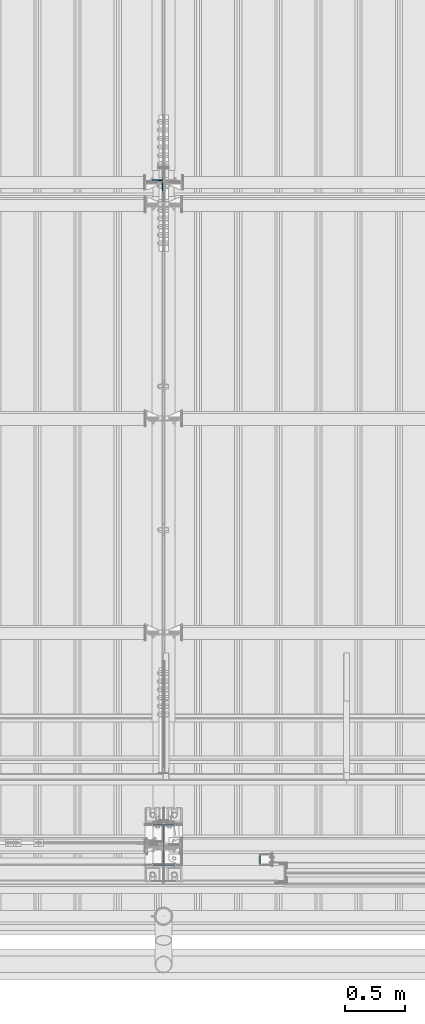
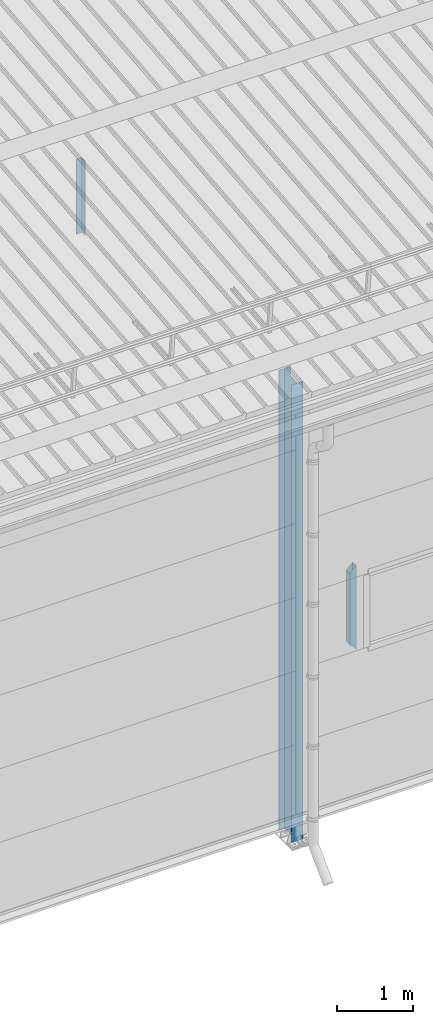
# One storey, part 229 of 709: 3 columns, 3 elements without a shape of their own.
"""IFC4 building model written with IfcOpenShell, lengths in millimetres."""

from ifc_helpers import new_model, si_unit, direction, frame, origin_with_axes, place, context, subcontext, project, spatial, polygons, material, element, aggregate, save


model = new_model("IFC4")

# Units and contexts
model_context = context("Model", 3, precision=0.2, world=origin_with_axes(), true_north=direction((0.0, 1.0)))
body_context = subcontext(model_context, "Body", "Model", "MODEL_VIEW")
ifc_project = project(units=[si_unit("LENGTHUNIT", "METRE", prefix="MILLI"), si_unit("AREAUNIT", "SQUARE_METRE"), si_unit("VOLUMEUNIT", "CUBIC_METRE"), si_unit("MASSUNIT", "GRAM", prefix="KILO"), si_unit("TIMEUNIT", "SECOND"), si_unit("PLANEANGLEUNIT", "RADIAN"), si_unit("SOLIDANGLEUNIT", "STERADIAN"), si_unit("THERMODYNAMICTEMPERATUREUNIT", "DEGREE_CELSIUS"), si_unit("LUMINOUSINTENSITYUNIT", "LUMEN")], contexts=[model_context])

# Site, building, storey
site_placement = place(None, origin_with_axes())
site = spatial("IfcSite", under=ifc_project, at=site_placement, CompositionType="ELEMENT")
building_placement = place(site_placement, origin_with_axes())
building = spatial("IfcBuilding", under=site, at=building_placement, Name="Undefined", CompositionType="ELEMENT")
storey_placement = place(building_placement, origin_with_axes())
storey = spatial("IfcBuildingStorey", under=building, at=storey_placement, Name="Undefined", CompositionType="ELEMENT", Elevation=0.0)

# Assembly, column
assembly_1_placement = place(storey_placement, frame((27949.0, 5648.7, 6024.30002), z_axis=(0.0, -1.0, 0.0), x_axis=(0.0, 0.0, 1.0)))
assembly_1 = element("IfcElementAssembly", 1, at=assembly_1_placement, inside=storey)
ifc_material_1 = material(Name="C345-5", Category="STEEL")
column_1_placement = place(assembly_1_placement, origin_with_axes())
column_1 = element("IfcColumn", 2, at=column_1_placement, material=ifc_material_1, ObjectType="436", context=body_context, shape_type="Tessellation", body=[
    polygons([(185.7, -45.0, -45.0), (185.7, 45.0, -45.0), (1399.0509, 45.0, -45.0), (1399.0509, -45.0, -45.0), (185.7, 45.0, -39.0), (1399.0509, 45.0, -39.0), (185.7, -39.0, -39.0), (1399.0509, -39.0, -39.0), (185.7, -39.0, 45.0), (1399.0509, -39.0, 45.0), (185.7, -45.0, 45.0), (1399.0509, -45.0, 45.0)], [[[1, 2, 3, 4]], [[2, 5, 6, 3]], [[5, 7, 8, 6]], [[7, 9, 10, 8]], [[9, 11, 12, 10]], [[11, 1, 4, 12]], [[6, 8, 10, 12, 4, 3]], [[11, 9, 7, 5, 2, 1]]], closed=True),
])
aggregate(assembly_1, [column_1])

assembly_2_placement = place(storey_placement, frame((28000.0, 173.0, -200.0), z_axis=(-1.0, 0.0, 0.0), x_axis=(0.0, 0.0, 1.0)))
assembly_2 = element("IfcElementAssembly", 3, at=assembly_2_placement, inside=storey)
ifc_material_2 = material(Name="C355-5", Category="STEEL")
column_2_placement = place(assembly_2_placement, origin_with_axes())
column_2 = element("IfcColumn", 4, at=column_2_placement, material=ifc_material_2, ObjectType="413", context=body_context, shape_type="Tessellation", body=[
    polygons([(25.0, -173.0, -87.0), (25.0, -164.0, -87.0), (7421.82297, -164.0, -87.0), (7420.92297, -173.0, -87.0), (25.0, -164.0, -3.0), (7421.82297, -164.0, -3.0), (25.0, 164.0, -3.0), (7454.62297, 164.0, -3.0), (25.0, 164.0, -87.0), (7454.62297, 164.0, -87.0), (25.0, 173.0, -87.0), (7455.52297, 173.0, -87.0), (25.0, 173.0, 87.0), (7455.52297, 173.0, 87.0), (25.0, 164.0, 87.0), (7454.62297, 164.0, 87.0), (25.0, 164.0, 3.0), (7454.62297, 164.0, 3.0), (25.0, -164.0, 3.0), (7421.82297, -164.0, 3.0), (25.0, -164.0, 87.0), (7421.82297, -164.0, 87.0), (25.0, -173.0, 87.0), (7420.92297, -173.0, 87.0)], [[[1, 2, 3, 4]], [[2, 5, 6, 3]], [[5, 7, 8, 6]], [[7, 9, 10, 8]], [[9, 11, 12, 10]], [[11, 13, 14, 12]], [[13, 15, 16, 14]], [[15, 17, 18, 16]], [[17, 19, 20, 18]], [[19, 21, 22, 20]], [[21, 23, 24, 22]], [[23, 1, 4, 24]], [[6, 8, 10, 12, 14, 16, 18, 20, 22, 24, 4, 3]], [[23, 21, 19, 17, 15, 13, 11, 9, 7, 5, 2, 1]]], closed=True),
])
aggregate(assembly_2, [column_2])

assembly_3_placement = place(storey_placement, frame((28850.0, 50.0, 2600.0), z_axis=(1.0, 0.0, 0.0), x_axis=(0.0, 0.0, 1.0)))
assembly_3 = element("IfcElementAssembly", 5, at=assembly_3_placement, inside=storey)
ifc_material_3 = material(Name="C355", Category="STEEL")
column_3_placement = place(assembly_3_placement, origin_with_axes())
column_3 = element("IfcColumn", 6, at=column_3_placement, material=ifc_material_3, ObjectType="493", context=body_context, shape_type="Tessellation", body=[
    polygons([(10.0, -50.0, 50.0), (110.0, -50.0, -50.0), (1260.0, -50.0, -50.0), (1360.0, -50.0, 50.0), (10.0, 50.0, 50.0), (1360.0, 50.0, 50.0), (110.0, 50.0, -50.0), (1260.0, 50.0, -50.0), (13.0, -47.0, 47.0), (13.0, 47.0, 47.0), (1357.0, 47.0, 47.0), (1357.0, -47.0, 47.0), (107.0, -47.0, -47.0), (1263.0, -47.0, -47.0), (107.0, 47.0, -47.0), (1263.0, 47.0, -47.0)], [[[1, 2, 3, 4]], [[5, 1, 4, 6]], [[7, 5, 6, 8]], [[2, 7, 8, 3]], [[1, 5, 7, 2], [9, 13, 15, 10]], [[9, 10, 11, 12]], [[13, 9, 12, 14]], [[15, 13, 14, 16]], [[10, 15, 16, 11]], [[3, 8, 6, 4], [14, 12, 11, 16]]], closed=True),
])
aggregate(assembly_3, [column_3])

save(model, "model.ifc")
